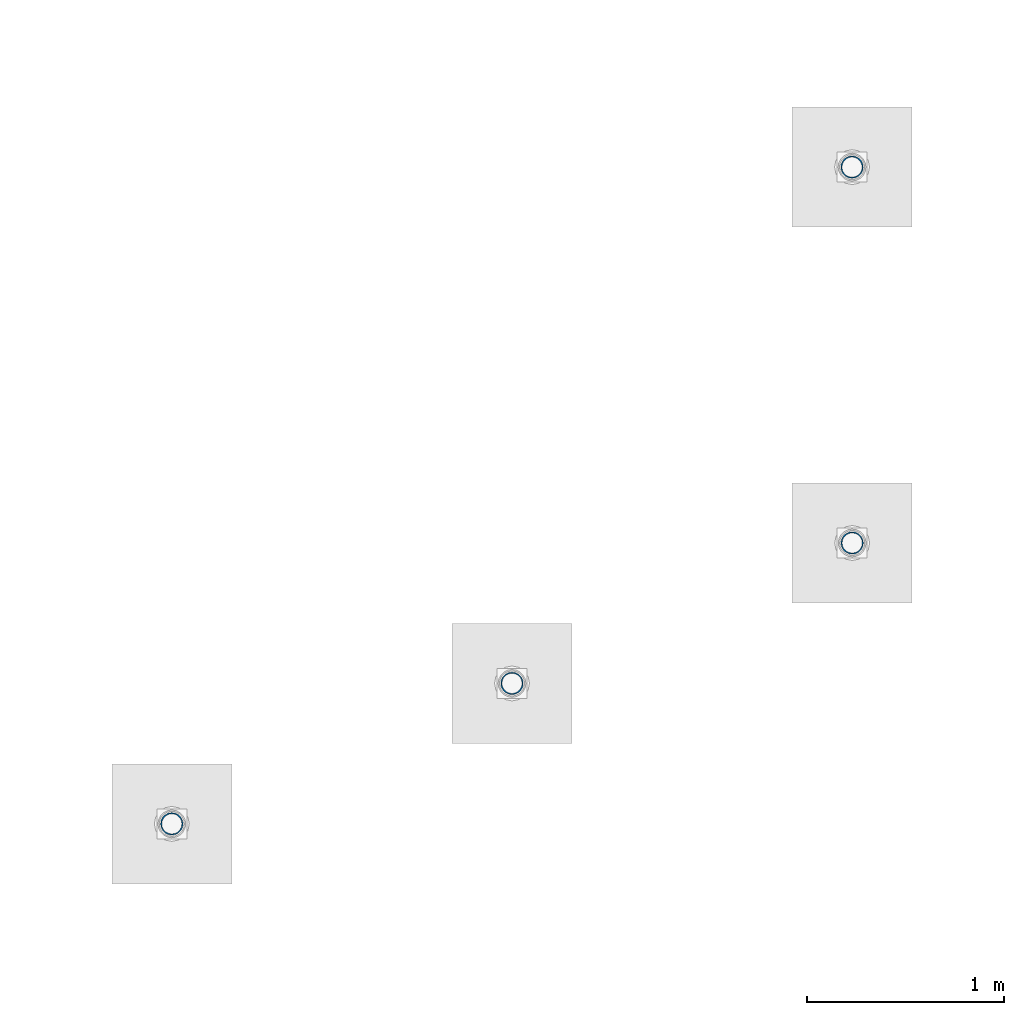
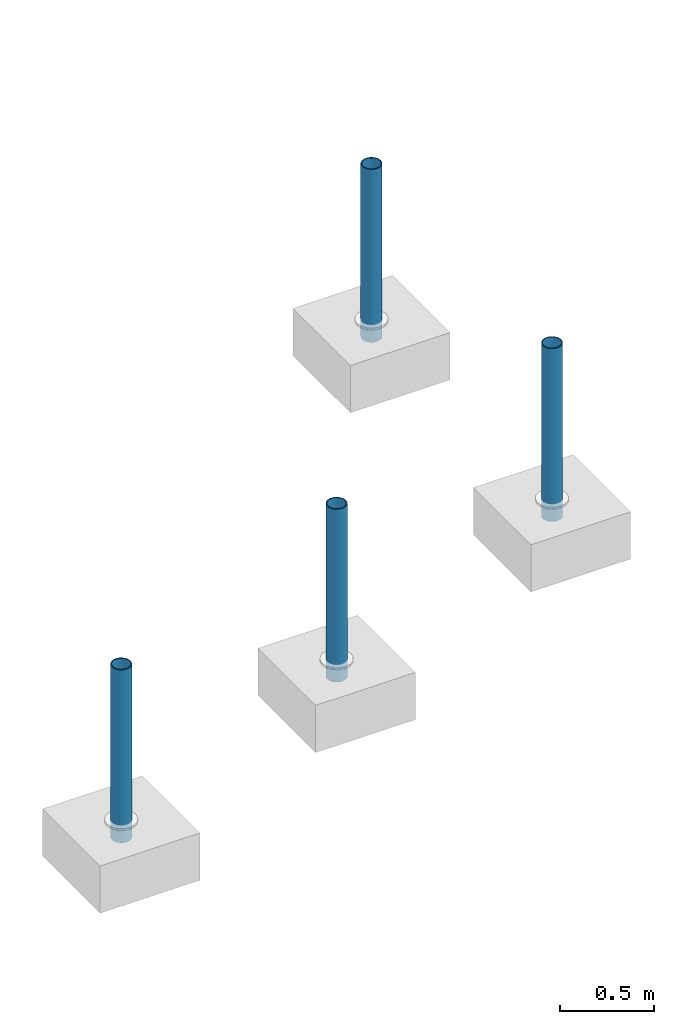
# One storey, part 1275 of 3843: 4 columns, 4 elements without a shape of their own.
"""IFC2X3 building model written with IfcOpenShell, lengths in millimetres."""

from ifc_helpers import new_model, si_unit, frame, origin_with_axes, place, context, subcontext, project, spatial, faceted_brep, material, type_object, element, aggregate, save


model = new_model("IFC2X3")

# Units and contexts
model_context = context("Model", 3, precision=1e-05, world=origin_with_axes())
body_context = subcontext(model_context, "Body", "Model", "MODEL_VIEW")
ifc_project = project(units=[si_unit("LENGTHUNIT", "METRE", prefix="MILLI"), si_unit("AREAUNIT", "SQUARE_METRE"), si_unit("VOLUMEUNIT", "CUBIC_METRE"), si_unit("MASSUNIT", "GRAM", prefix="KILO"), si_unit("TIMEUNIT", "SECOND"), si_unit("PLANEANGLEUNIT", "RADIAN"), si_unit("SOLIDANGLEUNIT", "STERADIAN"), si_unit("THERMODYNAMICTEMPERATUREUNIT", "DEGREE_CELSIUS"), si_unit("LUMINOUSINTENSITYUNIT", "LUMEN")], contexts=[model_context])

# Site, building, storey
site_placement = place(None, origin_with_axes())
site = spatial("IfcSite", under=ifc_project, at=site_placement, CompositionType="ELEMENT")
building_placement = place(site_placement, origin_with_axes())
building = spatial("IfcBuilding", under=site, at=building_placement, Name="Undefined", CompositionType="ELEMENT")
storey_placement = place(building_placement, origin_with_axes())
storey = spatial("IfcBuildingStorey", under=building, at=storey_placement, Name="Undefined", CompositionType="ELEMENT", Elevation=0.0)

# Assembly, column
assembly_1_placement = place(storey_placement, origin_with_axes())
assembly_1 = element("IfcElementAssembly", 1, at=assembly_1_placement, inside=storey, Name="PIPE_BOLLARD", AssemblyPlace="NOTDEFINED", PredefinedType="RIGID_FRAME")
ifc_material = material()
column_type = type_object("IfcColumnType", Name="PIPE4SCH40", PredefinedType="NOTDEFINED")
column_1_placement = place(assembly_1_placement, frame((3266.14378336072, 39556.0458376408, 30378.4), z_axis=(-1.0, 0.0, 0.0), x_axis=(0.0, 0.0, 1.0)))
column_1 = element("IfcColumn", 2, at=column_1_placement, type_object=column_type, material=ifc_material, Name="PIPE_BOLLARD", ObjectType="PIPE4SCH40", context=body_context, shape_type="Brep", body=[
    faceted_brep([(0.0, -51.1301999999996, 0.0), (0.0, -48.6277098894743, 15.8001007257844), (1117.6, -48.6277098894743, 15.8001007257844), (1117.6, -51.1301999999996, 0.0), (0.0, -41.3652007257897, 30.0535775067692), (1117.6, -41.3652007257897, 30.0535775067692), (0.0, -30.0535775067647, 41.3652007257915), (1117.6, -30.0535775067647, 41.3652007257915), (0.0, -15.8001007257899, 48.6277098894789), (1117.6, -15.8001007257899, 48.6277098894789), (0.0, 0.0, 51.1301999999996), (1117.6, 0.0, 51.1301999999996), (0.0, 15.8001007257899, 48.6277098894789), (1117.6, 15.8001007257899, 48.6277098894789), (0.0, 30.0535775067647, 41.3652007257915), (1117.6, 30.0535775067647, 41.3652007257915), (0.0, 41.3652007257897, 30.0535775067692), (1117.6, 41.3652007257897, 30.0535775067692), (0.0, 48.6277098894743, 15.8001007257844), (1117.6, 48.6277098894743, 15.8001007257844), (0.0, 51.1301999999996, 0.0), (1117.6, 51.1301999999996, 0.0), (0.0, 48.6277098894743, -15.8001007257844), (1117.6, 48.6277098894743, -15.8001007257844), (0.0, 41.3652007257897, -30.0535775067692), (1117.6, 41.3652007257897, -30.0535775067692), (0.0, 30.0535775067647, -41.3652007257915), (1117.6, 30.0535775067647, -41.3652007257915), (0.0, 15.8001007257899, -48.6277098894789), (1117.6, 15.8001007257899, -48.6277098894789), (0.0, 0.0, -51.1301999999996), (1117.6, 0.0, -51.1301999999996), (0.0, -15.8001007257899, -48.6277098894789), (1117.6, -15.8001007257899, -48.6277098894789), (0.0, -30.0535775067647, -41.3652007257915), (1117.6, -30.0535775067647, -41.3652007257915), (0.0, -41.3652007257897, -30.0535775067692), (1117.6, -41.3652007257897, -30.0535775067692), (0.0, -48.6277098894743, -15.8001007257844), (1117.6, -48.6277098894743, -15.8001007257844), (0.0, -57.1499999999996, 0.0), (0.0, -54.3528799062678, -17.6603212285263), (1117.6, -54.3528799062678, -17.6603212285263), (1117.6, -57.1499999999996, 0.0), (0.0, -46.2353212285279, -33.5919271685125), (1117.6, -46.2353212285279, -33.5919271685125), (0.0, -33.5919271685152, -46.2353212285234), (1117.6, -33.5919271685152, -46.2353212285234), (0.0, -17.6603212285281, -54.3528799062624), (1117.6, -17.6603212285281, -54.3528799062624), (0.0, 0.0, -57.1499999999942), (1117.6, 0.0, -57.1499999999942), (0.0, 17.6603212285281, -54.3528799062624), (1117.6, 17.6603212285281, -54.3528799062624), (0.0, 33.5919271685152, -46.2353212285234), (1117.6, 33.5919271685152, -46.2353212285234), (0.0, 46.2353212285279, -33.5919271685125), (1117.6, 46.2353212285279, -33.5919271685125), (0.0, 54.3528799062678, -17.6603212285263), (1117.6, 54.3528799062678, -17.6603212285263), (0.0, 57.1499999999996, 0.0), (1117.6, 57.1499999999996, 0.0), (0.0, 54.3528799062678, 17.6603212285263), (1117.6, 54.3528799062678, 17.6603212285263), (0.0, 46.2353212285279, 33.5919271685125), (1117.6, 46.2353212285279, 33.5919271685125), (0.0, 33.5919271685152, 46.2353212285234), (1117.6, 33.5919271685152, 46.2353212285234), (0.0, 17.6603212285281, 54.3528799062624), (1117.6, 17.6603212285281, 54.3528799062624), (0.0, 0.0, 57.1499999999942), (1117.6, 0.0, 57.1499999999942), (0.0, -17.6603212285281, 54.3528799062624), (1117.6, -17.6603212285281, 54.3528799062624), (0.0, -33.5919271685152, 46.2353212285234), (1117.6, -33.5919271685152, 46.2353212285234), (0.0, -46.2353212285279, 33.5919271685125), (1117.6, -46.2353212285279, 33.5919271685125), (0.0, -54.3528799062678, 17.6603212285263), (1117.6, -54.3528799062678, 17.6603212285263)], [[[0, 1, 2, 3]], [[1, 4, 5, 2]], [[4, 6, 7, 5]], [[6, 8, 9, 7]], [[8, 10, 11, 9]], [[10, 12, 13, 11]], [[12, 14, 15, 13]], [[14, 16, 17, 15]], [[16, 18, 19, 17]], [[18, 20, 21, 19]], [[20, 22, 23, 21]], [[22, 24, 25, 23]], [[24, 26, 27, 25]], [[26, 28, 29, 27]], [[28, 30, 31, 29]], [[30, 32, 33, 31]], [[32, 34, 35, 33]], [[34, 36, 37, 35]], [[36, 38, 39, 37]], [[38, 0, 3, 39]], [[40, 41, 42, 43]], [[41, 44, 45, 42]], [[44, 46, 47, 45]], [[46, 48, 49, 47]], [[48, 50, 51, 49]], [[50, 52, 53, 51]], [[52, 54, 55, 53]], [[54, 56, 57, 55]], [[56, 58, 59, 57]], [[58, 60, 61, 59]], [[60, 62, 63, 61]], [[62, 64, 65, 63]], [[64, 66, 67, 65]], [[66, 68, 69, 67]], [[68, 70, 71, 69]], [[70, 72, 73, 71]], [[72, 74, 75, 73]], [[74, 76, 77, 75]], [[76, 78, 79, 77]], [[78, 40, 43, 79]], [[45, 47, 49, 51, 53, 55, 57, 59, 61, 63, 65, 67, 69, 71, 73, 75, 77, 79, 43, 42], [5, 7, 9, 11, 13, 15, 17, 19, 21, 23, 25, 27, 29, 31, 33, 35, 37, 39, 3, 2]], [[78, 76, 74, 72, 70, 68, 66, 64, 62, 60, 58, 56, 54, 52, 50, 48, 46, 44, 41, 40], [38, 36, 34, 32, 30, 28, 26, 24, 22, 20, 18, 16, 14, 12, 10, 8, 6, 4, 1, 0]]]),
])
aggregate(assembly_1, [column_1])

assembly_2_placement = place(storey_placement, origin_with_axes())
assembly_2 = element("IfcElementAssembly", 3, at=assembly_2_placement, inside=storey, Name="PIPE_BOLLARD", AssemblyPlace="NOTDEFINED", PredefinedType="RIGID_FRAME")
column_2_placement = place(assembly_2_placement, frame((3266.91244485974, 37645.7255556583, 30378.4), z_axis=(-1.0, 0.0, 0.0), x_axis=(0.0, 0.0, 1.0)))
column_2 = element("IfcColumn", 4, at=column_2_placement, type_object=column_type, material=ifc_material, Name="PIPE_BOLLARD", ObjectType="PIPE4SCH40", context=body_context, shape_type="Brep", body=[
    faceted_brep([(0.0, -51.1301999999996, 0.0), (0.0, -48.6277098894743, 15.8001007257844), (1117.6, -48.6277098894743, 15.8001007257844), (1117.6, -51.1301999999996, 0.0), (0.0, -41.3652007257897, 30.0535775067692), (1117.6, -41.3652007257897, 30.0535775067692), (0.0, -30.0535775067647, 41.3652007257915), (1117.6, -30.0535775067647, 41.3652007257915), (0.0, -15.8001007257899, 48.6277098894789), (1117.6, -15.8001007257899, 48.6277098894789), (0.0, 0.0, 51.1301999999996), (1117.6, 0.0, 51.1301999999996), (0.0, 15.8001007257899, 48.6277098894789), (1117.6, 15.8001007257899, 48.6277098894789), (0.0, 30.0535775067647, 41.3652007257915), (1117.6, 30.0535775067647, 41.3652007257915), (0.0, 41.3652007257897, 30.0535775067692), (1117.6, 41.3652007257897, 30.0535775067692), (0.0, 48.6277098894743, 15.8001007257844), (1117.6, 48.6277098894743, 15.8001007257844), (0.0, 51.1301999999996, 0.0), (1117.6, 51.1301999999996, 0.0), (0.0, 48.6277098894743, -15.8001007257844), (1117.6, 48.6277098894743, -15.8001007257844), (0.0, 41.3652007257897, -30.0535775067692), (1117.6, 41.3652007257897, -30.0535775067692), (0.0, 30.0535775067647, -41.3652007257915), (1117.6, 30.0535775067647, -41.3652007257915), (0.0, 15.8001007257899, -48.6277098894789), (1117.6, 15.8001007257899, -48.6277098894789), (0.0, 0.0, -51.1301999999996), (1117.6, 0.0, -51.1301999999996), (0.0, -15.8001007257899, -48.6277098894789), (1117.6, -15.8001007257899, -48.6277098894789), (0.0, -30.0535775067647, -41.3652007257915), (1117.6, -30.0535775067647, -41.3652007257915), (0.0, -41.3652007257897, -30.0535775067692), (1117.6, -41.3652007257897, -30.0535775067692), (0.0, -48.6277098894743, -15.8001007257844), (1117.6, -48.6277098894743, -15.8001007257844), (0.0, -57.1499999999996, 0.0), (0.0, -54.3528799062678, -17.6603212285263), (1117.6, -54.3528799062678, -17.6603212285263), (1117.6, -57.1499999999996, 0.0), (0.0, -46.2353212285279, -33.5919271685125), (1117.6, -46.2353212285279, -33.5919271685125), (0.0, -33.5919271685152, -46.2353212285234), (1117.6, -33.5919271685152, -46.2353212285234), (0.0, -17.6603212285281, -54.3528799062624), (1117.6, -17.6603212285281, -54.3528799062624), (0.0, 0.0, -57.1499999999942), (1117.6, 0.0, -57.1499999999942), (0.0, 17.6603212285281, -54.3528799062624), (1117.6, 17.6603212285281, -54.3528799062624), (0.0, 33.5919271685152, -46.2353212285234), (1117.6, 33.5919271685152, -46.2353212285234), (0.0, 46.2353212285279, -33.5919271685125), (1117.6, 46.2353212285279, -33.5919271685125), (0.0, 54.3528799062678, -17.6603212285263), (1117.6, 54.3528799062678, -17.6603212285263), (0.0, 57.1499999999996, 0.0), (1117.6, 57.1499999999996, 0.0), (0.0, 54.3528799062678, 17.6603212285263), (1117.6, 54.3528799062678, 17.6603212285263), (0.0, 46.2353212285279, 33.5919271685125), (1117.6, 46.2353212285279, 33.5919271685125), (0.0, 33.5919271685152, 46.2353212285234), (1117.6, 33.5919271685152, 46.2353212285234), (0.0, 17.6603212285281, 54.3528799062624), (1117.6, 17.6603212285281, 54.3528799062624), (0.0, 0.0, 57.1499999999942), (1117.6, 0.0, 57.1499999999942), (0.0, -17.6603212285281, 54.3528799062624), (1117.6, -17.6603212285281, 54.3528799062624), (0.0, -33.5919271685152, 46.2353212285234), (1117.6, -33.5919271685152, 46.2353212285234), (0.0, -46.2353212285279, 33.5919271685125), (1117.6, -46.2353212285279, 33.5919271685125), (0.0, -54.3528799062678, 17.6603212285263), (1117.6, -54.3528799062678, 17.6603212285263)], [[[0, 1, 2, 3]], [[1, 4, 5, 2]], [[4, 6, 7, 5]], [[6, 8, 9, 7]], [[8, 10, 11, 9]], [[10, 12, 13, 11]], [[12, 14, 15, 13]], [[14, 16, 17, 15]], [[16, 18, 19, 17]], [[18, 20, 21, 19]], [[20, 22, 23, 21]], [[22, 24, 25, 23]], [[24, 26, 27, 25]], [[26, 28, 29, 27]], [[28, 30, 31, 29]], [[30, 32, 33, 31]], [[32, 34, 35, 33]], [[34, 36, 37, 35]], [[36, 38, 39, 37]], [[38, 0, 3, 39]], [[40, 41, 42, 43]], [[41, 44, 45, 42]], [[44, 46, 47, 45]], [[46, 48, 49, 47]], [[48, 50, 51, 49]], [[50, 52, 53, 51]], [[52, 54, 55, 53]], [[54, 56, 57, 55]], [[56, 58, 59, 57]], [[58, 60, 61, 59]], [[60, 62, 63, 61]], [[62, 64, 65, 63]], [[64, 66, 67, 65]], [[66, 68, 69, 67]], [[68, 70, 71, 69]], [[70, 72, 73, 71]], [[72, 74, 75, 73]], [[74, 76, 77, 75]], [[76, 78, 79, 77]], [[78, 40, 43, 79]], [[45, 47, 49, 51, 53, 55, 57, 59, 61, 63, 65, 67, 69, 71, 73, 75, 77, 79, 43, 42], [5, 7, 9, 11, 13, 15, 17, 19, 21, 23, 25, 27, 29, 31, 33, 35, 37, 39, 3, 2]], [[78, 76, 74, 72, 70, 68, 66, 64, 62, 60, 58, 56, 54, 52, 50, 48, 46, 44, 41, 40], [38, 36, 34, 32, 30, 28, 26, 24, 22, 20, 18, 16, 14, 12, 10, 8, 6, 4, 1, 0]]]),
])
aggregate(assembly_2, [column_2])

assembly_3_placement = place(storey_placement, origin_with_axes())
assembly_3 = element("IfcElementAssembly", 5, at=assembly_3_placement, inside=storey, Name="PIPE_BOLLARD", AssemblyPlace="NOTDEFINED", PredefinedType="RIGID_FRAME")
column_3_placement = place(assembly_3_placement, frame((1538.06970956921, 36931.9728090763, 30378.4), z_axis=(-1.0, 0.0, 0.0), x_axis=(0.0, 0.0, 1.0)))
column_3 = element("IfcColumn", 6, at=column_3_placement, type_object=column_type, material=ifc_material, Name="PIPE_BOLLARD", ObjectType="PIPE4SCH40", context=body_context, shape_type="Brep", body=[
    faceted_brep([(0.0, -51.1301999999996, 0.0), (0.0, -48.6277098894743, 15.8001007257844), (1117.6, -48.6277098894743, 15.8001007257844), (1117.6, -51.1301999999996, 0.0), (0.0, -41.3652007257897, 30.0535775067692), (1117.6, -41.3652007257897, 30.0535775067692), (0.0, -30.0535775067647, 41.3652007257915), (1117.6, -30.0535775067647, 41.3652007257915), (0.0, -15.8001007257899, 48.6277098894789), (1117.6, -15.8001007257899, 48.6277098894789), (0.0, 0.0, 51.1301999999996), (1117.6, 0.0, 51.1301999999996), (0.0, 15.8001007257899, 48.6277098894789), (1117.6, 15.8001007257899, 48.6277098894789), (0.0, 30.0535775067647, 41.3652007257915), (1117.6, 30.0535775067647, 41.3652007257915), (0.0, 41.3652007257897, 30.0535775067692), (1117.6, 41.3652007257897, 30.0535775067692), (0.0, 48.6277098894743, 15.8001007257844), (1117.6, 48.6277098894743, 15.8001007257844), (0.0, 51.1301999999996, 0.0), (1117.6, 51.1301999999996, 0.0), (0.0, 48.6277098894743, -15.8001007257844), (1117.6, 48.6277098894743, -15.8001007257844), (0.0, 41.3652007257897, -30.0535775067692), (1117.6, 41.3652007257897, -30.0535775067692), (0.0, 30.0535775067647, -41.3652007257915), (1117.6, 30.0535775067647, -41.3652007257915), (0.0, 15.8001007257899, -48.6277098894789), (1117.6, 15.8001007257899, -48.6277098894789), (0.0, 0.0, -51.1301999999996), (1117.6, 0.0, -51.1301999999996), (0.0, -15.8001007257899, -48.6277098894789), (1117.6, -15.8001007257899, -48.6277098894789), (0.0, -30.0535775067647, -41.3652007257915), (1117.6, -30.0535775067647, -41.3652007257915), (0.0, -41.3652007257897, -30.0535775067692), (1117.6, -41.3652007257897, -30.0535775067692), (0.0, -48.6277098894743, -15.8001007257844), (1117.6, -48.6277098894743, -15.8001007257844), (0.0, -57.1499999999996, 0.0), (0.0, -54.3528799062678, -17.6603212285263), (1117.6, -54.3528799062678, -17.6603212285263), (1117.6, -57.1499999999996, 0.0), (0.0, -46.2353212285279, -33.5919271685125), (1117.6, -46.2353212285279, -33.5919271685125), (0.0, -33.5919271685152, -46.2353212285234), (1117.6, -33.5919271685152, -46.2353212285234), (0.0, -17.6603212285281, -54.3528799062624), (1117.6, -17.6603212285281, -54.3528799062624), (0.0, 0.0, -57.1499999999942), (1117.6, 0.0, -57.1499999999942), (0.0, 17.6603212285281, -54.3528799062624), (1117.6, 17.6603212285281, -54.3528799062624), (0.0, 33.5919271685152, -46.2353212285234), (1117.6, 33.5919271685152, -46.2353212285234), (0.0, 46.2353212285279, -33.5919271685125), (1117.6, 46.2353212285279, -33.5919271685125), (0.0, 54.3528799062678, -17.6603212285263), (1117.6, 54.3528799062678, -17.6603212285263), (0.0, 57.1499999999996, 0.0), (1117.6, 57.1499999999996, 0.0), (0.0, 54.3528799062678, 17.6603212285263), (1117.6, 54.3528799062678, 17.6603212285263), (0.0, 46.2353212285279, 33.5919271685125), (1117.6, 46.2353212285279, 33.5919271685125), (0.0, 33.5919271685152, 46.2353212285234), (1117.6, 33.5919271685152, 46.2353212285234), (0.0, 17.6603212285281, 54.3528799062624), (1117.6, 17.6603212285281, 54.3528799062624), (0.0, 0.0, 57.1499999999942), (1117.6, 0.0, 57.1499999999942), (0.0, -17.6603212285281, 54.3528799062624), (1117.6, -17.6603212285281, 54.3528799062624), (0.0, -33.5919271685152, 46.2353212285234), (1117.6, -33.5919271685152, 46.2353212285234), (0.0, -46.2353212285279, 33.5919271685125), (1117.6, -46.2353212285279, 33.5919271685125), (0.0, -54.3528799062678, 17.6603212285263), (1117.6, -54.3528799062678, 17.6603212285263)], [[[0, 1, 2, 3]], [[1, 4, 5, 2]], [[4, 6, 7, 5]], [[6, 8, 9, 7]], [[8, 10, 11, 9]], [[10, 12, 13, 11]], [[12, 14, 15, 13]], [[14, 16, 17, 15]], [[16, 18, 19, 17]], [[18, 20, 21, 19]], [[20, 22, 23, 21]], [[22, 24, 25, 23]], [[24, 26, 27, 25]], [[26, 28, 29, 27]], [[28, 30, 31, 29]], [[30, 32, 33, 31]], [[32, 34, 35, 33]], [[34, 36, 37, 35]], [[36, 38, 39, 37]], [[38, 0, 3, 39]], [[40, 41, 42, 43]], [[41, 44, 45, 42]], [[44, 46, 47, 45]], [[46, 48, 49, 47]], [[48, 50, 51, 49]], [[50, 52, 53, 51]], [[52, 54, 55, 53]], [[54, 56, 57, 55]], [[56, 58, 59, 57]], [[58, 60, 61, 59]], [[60, 62, 63, 61]], [[62, 64, 65, 63]], [[64, 66, 67, 65]], [[66, 68, 69, 67]], [[68, 70, 71, 69]], [[70, 72, 73, 71]], [[72, 74, 75, 73]], [[74, 76, 77, 75]], [[76, 78, 79, 77]], [[78, 40, 43, 79]], [[45, 47, 49, 51, 53, 55, 57, 59, 61, 63, 65, 67, 69, 71, 73, 75, 77, 79, 43, 42], [5, 7, 9, 11, 13, 15, 17, 19, 21, 23, 25, 27, 29, 31, 33, 35, 37, 39, 3, 2]], [[78, 76, 74, 72, 70, 68, 66, 64, 62, 60, 58, 56, 54, 52, 50, 48, 46, 44, 41, 40], [38, 36, 34, 32, 30, 28, 26, 24, 22, 20, 18, 16, 14, 12, 10, 8, 6, 4, 1, 0]]]),
])
aggregate(assembly_3, [column_3])

assembly_4_placement = place(storey_placement, origin_with_axes())
assembly_4 = element("IfcElementAssembly", 7, at=assembly_4_placement, inside=storey, Name="PIPE_BOLLARD", AssemblyPlace="NOTDEFINED", PredefinedType="RIGID_FRAME")
column_4_placement = place(assembly_4_placement, frame((-190.773025721313, 36218.216247797, 30378.4), z_axis=(-1.0, 0.0, 0.0), x_axis=(0.0, 0.0, 1.0)))
column_4 = element("IfcColumn", 8, at=column_4_placement, type_object=column_type, material=ifc_material, Name="PIPE_BOLLARD", ObjectType="PIPE4SCH40", context=body_context, shape_type="Brep", body=[
    faceted_brep([(0.0, -51.1301999999996, 0.0), (0.0, -48.6277098894743, 15.8001007257844), (1117.6, -48.6277098894743, 15.8001007257844), (1117.6, -51.1301999999996, 0.0), (0.0, -41.3652007257897, 30.0535775067692), (1117.6, -41.3652007257897, 30.0535775067692), (0.0, -30.0535775067647, 41.3652007257915), (1117.6, -30.0535775067647, 41.3652007257915), (0.0, -15.8001007257899, 48.6277098894789), (1117.6, -15.8001007257899, 48.6277098894789), (0.0, 0.0, 51.1301999999996), (1117.6, 0.0, 51.1301999999996), (0.0, 15.8001007257899, 48.6277098894789), (1117.6, 15.8001007257899, 48.6277098894789), (0.0, 30.0535775067647, 41.3652007257915), (1117.6, 30.0535775067647, 41.3652007257915), (0.0, 41.3652007257897, 30.0535775067692), (1117.6, 41.3652007257897, 30.0535775067692), (0.0, 48.6277098894743, 15.8001007257844), (1117.6, 48.6277098894743, 15.8001007257844), (0.0, 51.1301999999996, 0.0), (1117.6, 51.1301999999996, 0.0), (0.0, 48.6277098894743, -15.8001007257844), (1117.6, 48.6277098894743, -15.8001007257844), (0.0, 41.3652007257897, -30.0535775067692), (1117.6, 41.3652007257897, -30.0535775067692), (0.0, 30.0535775067647, -41.3652007257915), (1117.6, 30.0535775067647, -41.3652007257915), (0.0, 15.8001007257899, -48.6277098894789), (1117.6, 15.8001007257899, -48.6277098894789), (0.0, 0.0, -51.1301999999996), (1117.6, 0.0, -51.1301999999996), (0.0, -15.8001007257899, -48.6277098894789), (1117.6, -15.8001007257899, -48.6277098894789), (0.0, -30.0535775067647, -41.3652007257915), (1117.6, -30.0535775067647, -41.3652007257915), (0.0, -41.3652007257897, -30.0535775067692), (1117.6, -41.3652007257897, -30.0535775067692), (0.0, -48.6277098894743, -15.8001007257844), (1117.6, -48.6277098894743, -15.8001007257844), (0.0, -57.1499999999996, 0.0), (0.0, -54.3528799062678, -17.6603212285263), (1117.6, -54.3528799062678, -17.6603212285263), (1117.6, -57.1499999999996, 0.0), (0.0, -46.2353212285279, -33.5919271685125), (1117.6, -46.2353212285279, -33.5919271685125), (0.0, -33.5919271685152, -46.2353212285234), (1117.6, -33.5919271685152, -46.2353212285234), (0.0, -17.6603212285281, -54.3528799062624), (1117.6, -17.6603212285281, -54.3528799062624), (0.0, 0.0, -57.1499999999942), (1117.6, 0.0, -57.1499999999942), (0.0, 17.6603212285281, -54.3528799062624), (1117.6, 17.6603212285281, -54.3528799062624), (0.0, 33.5919271685152, -46.2353212285234), (1117.6, 33.5919271685152, -46.2353212285234), (0.0, 46.2353212285279, -33.5919271685125), (1117.6, 46.2353212285279, -33.5919271685125), (0.0, 54.3528799062678, -17.6603212285263), (1117.6, 54.3528799062678, -17.6603212285263), (0.0, 57.1499999999996, 0.0), (1117.6, 57.1499999999996, 0.0), (0.0, 54.3528799062678, 17.6603212285263), (1117.6, 54.3528799062678, 17.6603212285263), (0.0, 46.2353212285279, 33.5919271685125), (1117.6, 46.2353212285279, 33.5919271685125), (0.0, 33.5919271685152, 46.2353212285234), (1117.6, 33.5919271685152, 46.2353212285234), (0.0, 17.6603212285281, 54.3528799062624), (1117.6, 17.6603212285281, 54.3528799062624), (0.0, 0.0, 57.1499999999942), (1117.6, 0.0, 57.1499999999942), (0.0, -17.6603212285281, 54.3528799062624), (1117.6, -17.6603212285281, 54.3528799062624), (0.0, -33.5919271685152, 46.2353212285234), (1117.6, -33.5919271685152, 46.2353212285234), (0.0, -46.2353212285279, 33.5919271685125), (1117.6, -46.2353212285279, 33.5919271685125), (0.0, -54.3528799062678, 17.6603212285263), (1117.6, -54.3528799062678, 17.6603212285263)], [[[0, 1, 2, 3]], [[1, 4, 5, 2]], [[4, 6, 7, 5]], [[6, 8, 9, 7]], [[8, 10, 11, 9]], [[10, 12, 13, 11]], [[12, 14, 15, 13]], [[14, 16, 17, 15]], [[16, 18, 19, 17]], [[18, 20, 21, 19]], [[20, 22, 23, 21]], [[22, 24, 25, 23]], [[24, 26, 27, 25]], [[26, 28, 29, 27]], [[28, 30, 31, 29]], [[30, 32, 33, 31]], [[32, 34, 35, 33]], [[34, 36, 37, 35]], [[36, 38, 39, 37]], [[38, 0, 3, 39]], [[40, 41, 42, 43]], [[41, 44, 45, 42]], [[44, 46, 47, 45]], [[46, 48, 49, 47]], [[48, 50, 51, 49]], [[50, 52, 53, 51]], [[52, 54, 55, 53]], [[54, 56, 57, 55]], [[56, 58, 59, 57]], [[58, 60, 61, 59]], [[60, 62, 63, 61]], [[62, 64, 65, 63]], [[64, 66, 67, 65]], [[66, 68, 69, 67]], [[68, 70, 71, 69]], [[70, 72, 73, 71]], [[72, 74, 75, 73]], [[74, 76, 77, 75]], [[76, 78, 79, 77]], [[78, 40, 43, 79]], [[45, 47, 49, 51, 53, 55, 57, 59, 61, 63, 65, 67, 69, 71, 73, 75, 77, 79, 43, 42], [5, 7, 9, 11, 13, 15, 17, 19, 21, 23, 25, 27, 29, 31, 33, 35, 37, 39, 3, 2]], [[78, 76, 74, 72, 70, 68, 66, 64, 62, 60, 58, 56, 54, 52, 50, 48, 46, 44, 41, 40], [38, 36, 34, 32, 30, 28, 26, 24, 22, 20, 18, 16, 14, 12, 10, 8, 6, 4, 1, 0]]]),
])
aggregate(assembly_4, [column_4])

save(model, "model.ifc")
